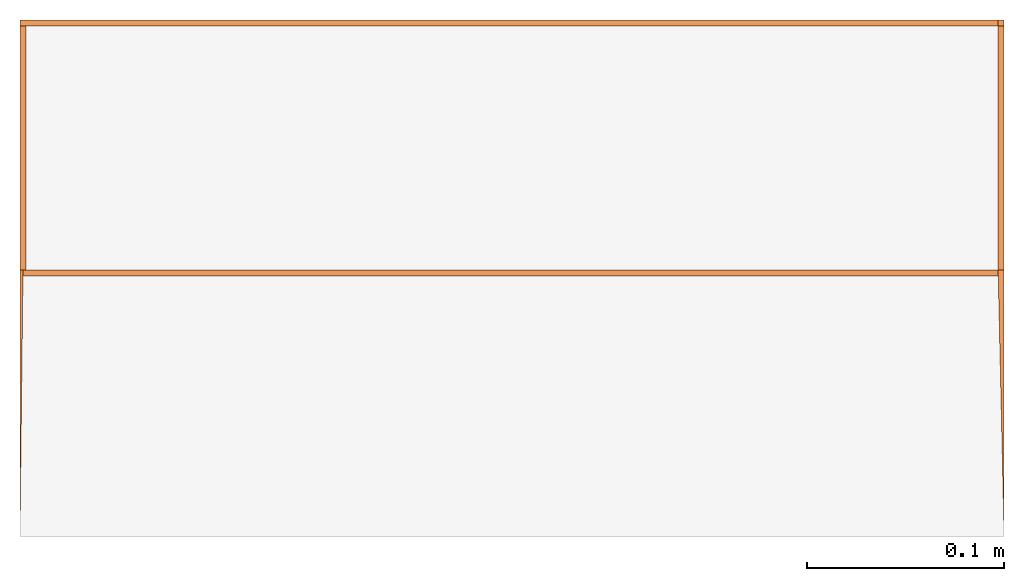
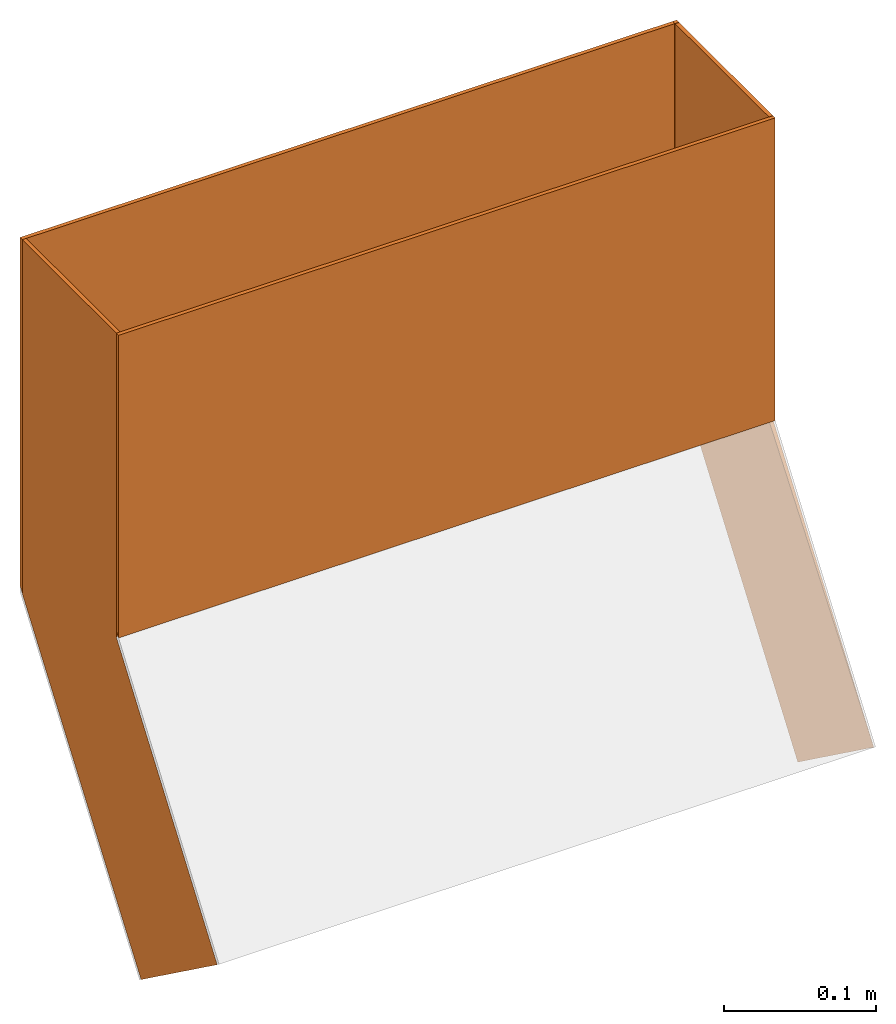
# One storey, part 2 of 2: 5 proxies.
"""IFC2X3 building model written with IfcOpenShell, lengths in metres."""

from ifc_helpers import new_model, entity, si_unit, converted_unit, derived_unit, money_unit, direction, frame, origin_with_axes, place, context, subcontext, project, spatial, polyline, outline, extrude, boolean, faceted_brep, material, type_object, element, save


model = new_model("IFC2X3")

# Units and contexts
model_context = context("Model", 3, precision=1e-05, world=origin_with_axes(), true_north=direction((0.0, 1.0)))
plan_context = context("Plan", 3, precision=1e-05, world=origin_with_axes(), true_north=direction((0.0, 1.0)))
body_context = subcontext(model_context, "Body", "Model", "MODEL_VIEW")
ifc_project = project(units=[si_unit("LENGTHUNIT", "METRE"), si_unit("AREAUNIT", "SQUARE_METRE"), si_unit("VOLUMEUNIT", "CUBIC_METRE"), converted_unit("PLANEANGLEUNIT", "DEGREE", entity("IfcPlaneAngleMeasure", 0.0174532925199), si_unit("PLANEANGLEUNIT", "RADIAN"), dimensions=[0, 0, 0, 0, 0, 0, 0]), si_unit("SOLIDANGLEUNIT", "STERADIAN"), money_unit("CHF"), converted_unit("TIMEUNIT", "Year", entity("IfcTimeMeasure", 31556926.0), si_unit("TIMEUNIT", "SECOND"), dimensions=[0, 0, 1, 0, 0, 0, 0]), si_unit("MASSUNIT", "GRAM", prefix="KILO"), si_unit("THERMODYNAMICTEMPERATUREUNIT", "DEGREE_CELSIUS"), si_unit("LUMINOUSINTENSITYUNIT", "LUMEN"), si_unit("ENERGYUNIT", "JOULE", prefix="MEGA"), derived_unit("THERMALCONDUCTANCEUNIT", [(si_unit("POWERUNIT", "WATT"), 1), (si_unit("LENGTHUNIT", "METRE"), -1), (si_unit("THERMODYNAMICTEMPERATUREUNIT", "KELVIN"), -1)]), derived_unit("SPECIFICHEATCAPACITYUNIT", [(si_unit("ENERGYUNIT", "JOULE"), 1), (si_unit("MASSUNIT", "GRAM", prefix="KILO"), -1), (si_unit("THERMODYNAMICTEMPERATUREUNIT", "KELVIN"), -1)]), derived_unit("MASSDENSITYUNIT", [(si_unit("MASSUNIT", "GRAM", prefix="KILO"), 1), (si_unit("VOLUMEUNIT", "CUBIC_METRE"), -1)])], contexts=[model_context, plan_context])

# Site, building, storey
site_placement = place(None, origin_with_axes())
site = spatial("IfcSite", under=ifc_project, at=site_placement, CompositionType="ELEMENT")
building_placement = place(site_placement, origin_with_axes())
building = spatial("IfcBuilding", under=site, at=building_placement, CompositionType="ELEMENT")
storey_placement = place(building_placement, frame((0.0, 0.0, -2.96), z_axis=(0.0, 0.0, 1.0), x_axis=(1.0, 0.0, 0.0)))
storey = spatial("IfcBuildingStorey", under=building, at=storey_placement, Name="UG01", CompositionType="ELEMENT", Elevation=-2.96)

# Proxies
ifc_material = material(Name="Metall, Stahl")
building_element_proxy_type_1 = type_object("IfcBuildingElementProxyType", Name="Metall, Stahl 3", PredefinedType="NOTDEFINED")
proxy_1_placement = place(storey_placement, frame((9.11522436818, -8.22743070606, 2.535), z_axis=(0.0, 0.0, 1.0), x_axis=(1.0, 0.0, 0.0)))
element("IfcBuildingElementProxy", 1, at=proxy_1_placement, inside=storey, type_object=building_element_proxy_type_1, material=ifc_material, Name="Wand-026", context=body_context, shape_type="CSG", body=[
    boolean("DIFFERENCE", extrude(outline(polyline([(0.0, 0.0), (0.5, 0.0), (0.5, 0.003), (0.0, 0.003), (0.0, 0.0)])), origin_with_axes(), (0.0, 0.0, 1.0), 0.425), faceted_brep([(1.96227034621e-10, 0.00299999974579, 0.18551039045), (0.500000000134, 0.00299999974579, 0.18551039045), (0.5, 0.003, 0.0), (0.0, 0.003, 0.0), (0.500000000134, 0.0, 0.181381245039), (1.96227034621e-10, 0.0, 0.181381245039), (0.5, 0.0, 0.0), (0.0, 0.0, 0.0)], [[[0, 1, 2, 3]], [[4, 1, 0, 5]], [[1, 4, 6, 2]], [[6, 7, 3, 2]], [[5, 0, 3, 7]], [[4, 5, 7, 6]]])),
])
proxy_2_placement = place(storey_placement, frame((9.61522436818, -8.22743070606, 2.535), z_axis=(0.0, 0.0, 1.0), x_axis=(0.0, 1.0, 0.0)))
element("IfcBuildingElementProxy", 2, at=proxy_2_placement, inside=storey, type_object=building_element_proxy_type_1, material=ifc_material, Name="Wand-027", context=body_context, shape_type="CSG", body=[
    boolean("DIFFERENCE", extrude(outline(polyline([(0.0, 0.0), (0.13, 0.0), (0.13, 0.003), (0.0, 0.003), (0.0, 0.0)])), origin_with_axes(), (0.0, 0.0, 1.0), 0.425), faceted_brep([(0.129999999746, 0.003, 0.14472378474), (0.129999999746, -1.33749011866e-10, 0.14472378474), (0.13, 0.0, 0.0), (0.13, 0.003, 0.0), (0.126999999771, -1.76727965595e-10, 0.140594639013), (0.126999999771, 0.00299999982327, 0.140594639013), (0.126999999771, -1.76727965595e-10, 0.425), (0.0, 0.0, 0.425), (0.0, 0.0, 0.0), (0.0, 0.003, 0.0), (0.0, 0.003, 0.425), (0.126999999771, 0.00299999982327, 0.425)], [[[0, 1, 2, 3]], [[4, 1, 0, 5]], [[4, 6, 7, 8, 2, 1]], [[2, 8, 9, 3]], [[5, 0, 3, 9, 10, 11]], [[11, 6, 4, 5]], [[6, 11, 10, 7]], [[10, 9, 8, 7]]])),
])
proxy_3_placement = place(storey_placement, frame((9.61522436818, -8.09743070606, 2.535), z_axis=(0.0, 0.0, 1.0), x_axis=(-1.0, 0.0, 0.0)))
element("IfcBuildingElementProxy", 3, at=proxy_3_placement, inside=storey, type_object=building_element_proxy_type_1, material=ifc_material, Name="Wand-028", context=body_context, shape_type="CSG", body=[
    boolean("DIFFERENCE", extrude(outline(polyline([(0.0, 0.0), (0.5, 0.0), (0.5, 0.003), (0.0, 0.003), (0.0, 0.0)])), origin_with_axes(), (0.0, 0.0, 1.0), 0.425), faceted_brep([(0.499999999804, 2.54210874573e-10, 0.14472378474), (0.003, 2.54210874573e-10, 0.14472378474), (0.003, 0.0, 0.425), (0.0, 0.0, 0.425), (0.0, 0.0, 0.0), (0.5, 0.0, 0.0), (0.499999999804, 0.003, 0.140594639328), (0.003, 0.003, 0.140594639328), (0.003, 0.003, 0.425), (0.0, 0.003, 0.425), (0.0, 0.003, 0.0), (0.5, 0.003, 0.0)], [[[0, 1, 2, 3, 4, 5]], [[1, 0, 6, 7]], [[8, 2, 1, 7]], [[2, 8, 9, 3]], [[9, 10, 4, 3]], [[5, 4, 10, 11]], [[6, 0, 5, 11]], [[7, 6, 11, 10, 9, 8]]])),
])
building_element_proxy_type_2 = type_object("IfcBuildingElementProxyType", Name="Metall, Stahl", PredefinedType="NOTDEFINED")
proxy_4_placement = place(storey_placement, frame((1.76729741952e-10, -2.2894930396e-10, 2.96), z_axis=(0.0, 0.0, 1.0), x_axis=(1.0, 0.0, 0.0)))
element("IfcBuildingElementProxy", 4, at=proxy_4_placement, inside=storey, type_object=building_element_proxy_type_2, material=ifc_material, Name="Wand-027", context=body_context, shape_type="Brep", body=[
    faceted_brep([(9.61222436818, -8.22443070606, -0.24462570871), (9.61222436818, -8.22443070606, 0.0), (9.61222436818, -8.10043070606, 0.0), (9.61222436818, -8.10043070606, -0.24462570871), (9.61522436818, -8.22443070606, -0.24462570871), (9.61522436818, -8.22443070606, 0.0), (9.61522436818, -8.10043070606, 0.0), (9.61522436818, -8.10043070606, -0.24462570871), (9.61522436818, -8.10043070606, -0.284915751472), (9.61522436857, -8.357484916, -0.427759118136), (9.61522436818, -8.2571357257, -0.500601707353)], [[[0, 1, 2, 3]], [[1, 0, 4, 5]], [[2, 1, 5, 6]], [[3, 2, 6, 7]], [[0, 3, 8]], [[4, 0, 9]], [[5, 4, 9, 10, 8, 7, 6]], [[3, 7, 8]], [[10, 0, 8]], [[0, 10, 9]]]),
])
proxy_5_placement = place(storey_placement, frame((1.76729741952e-10, -2.2894930396e-10, 2.96), z_axis=(0.0, 0.0, 1.0), x_axis=(1.0, 0.0, 0.0)))
element("IfcBuildingElementProxy", 5, at=proxy_5_placement, inside=storey, type_object=building_element_proxy_type_2, material=ifc_material, Name="Wand-029", context=body_context, shape_type="Brep", body=[
    faceted_brep([(9.11522436818, -8.2571357257, -0.500601707353), (9.115224368, -8.357484916, -0.427759118136), (9.115224368, -8.22443070583, -0.244625708824), (9.11522436818, -8.22443070606, 0.0), (9.11522436818, -8.10043070606, 0.0), (9.11522436818, -8.10043070606, -0.284915751472), (9.11822436818, -8.10043070606, -0.244129145761), (9.11822436818, -8.22443070606, -0.244129145761), (9.11822436818, -8.22443070606, 0.0), (9.11822436818, -8.10043070606, 0.0)], [[[0, 1, 2, 3, 4, 5]], [[1, 0, 6]], [[2, 1, 6]], [[3, 2, 7, 8]], [[4, 3, 8, 9]], [[6, 5, 4, 9]], [[0, 5, 6]], [[7, 2, 6]], [[8, 7, 6, 9]]]),
])

save(model, "model.ifc")
